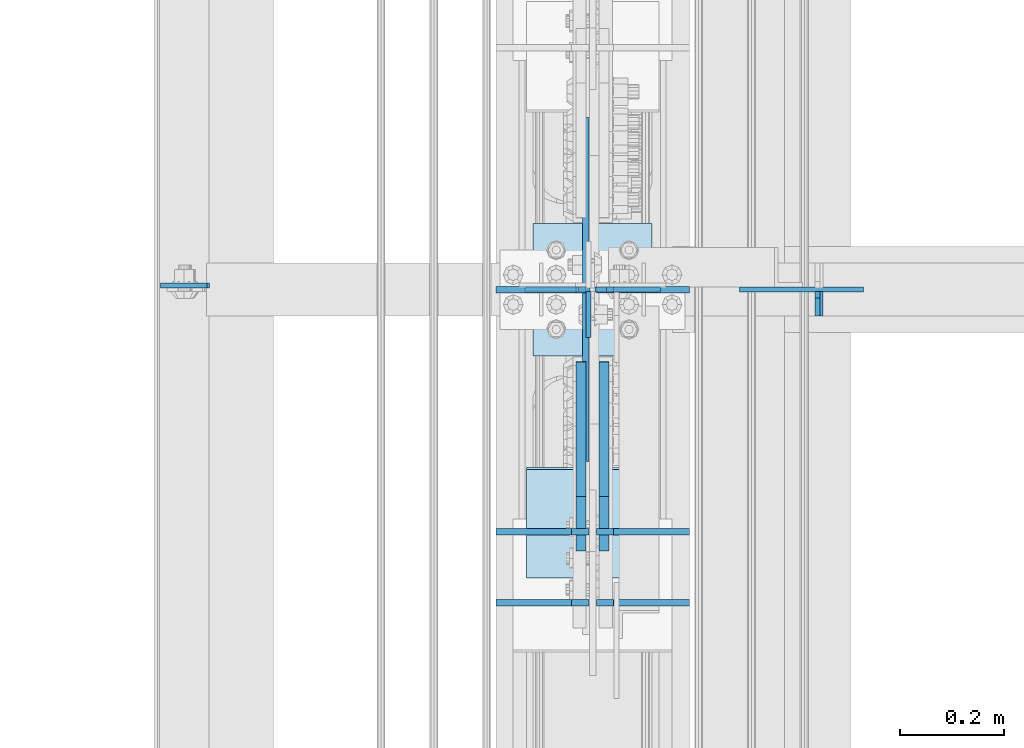
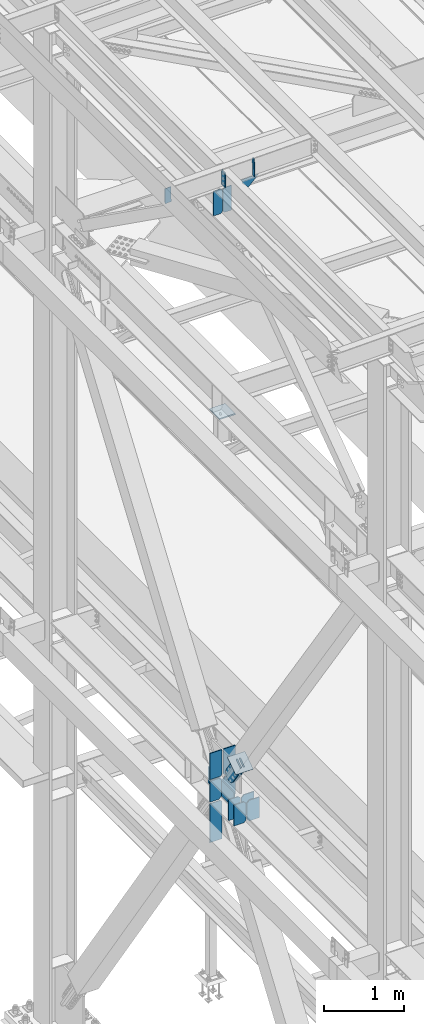
# One storey, part 3254 of 3843: 20 plates, 8 elements without a shape of their own.
"""IFC2X3 building model written with IfcOpenShell, lengths in millimetres."""

from ifc_helpers import new_model, si_unit, frame, origin_with_axes, place, context, subcontext, project, spatial, faceted_brep, material, type_object, element, aggregate, save


model = new_model("IFC2X3")

# Units and contexts
model_context = context("Model", 3, precision=1e-05, world=origin_with_axes())
body_context = subcontext(model_context, "Body", "Model", "MODEL_VIEW")
ifc_project = project(units=[si_unit("LENGTHUNIT", "METRE", prefix="MILLI"), si_unit("AREAUNIT", "SQUARE_METRE"), si_unit("VOLUMEUNIT", "CUBIC_METRE"), si_unit("MASSUNIT", "GRAM", prefix="KILO"), si_unit("TIMEUNIT", "SECOND"), si_unit("PLANEANGLEUNIT", "RADIAN"), si_unit("SOLIDANGLEUNIT", "STERADIAN"), si_unit("THERMODYNAMICTEMPERATUREUNIT", "DEGREE_CELSIUS"), si_unit("LUMINOUSINTENSITYUNIT", "LUMEN")], contexts=[model_context])

# Site, building, storey
site_placement = place(None, origin_with_axes())
site = spatial("IfcSite", under=ifc_project, at=site_placement, CompositionType="ELEMENT")
building_placement = place(site_placement, origin_with_axes())
building = spatial("IfcBuilding", under=site, at=building_placement, Name="Undefined", CompositionType="ELEMENT")
storey_placement = place(building_placement, origin_with_axes())
storey = spatial("IfcBuildingStorey", under=building, at=storey_placement, Name="Undefined", CompositionType="ELEMENT", Elevation=0.0)

# Assembly, plate
assembly_1_placement = place(storey_placement, origin_with_axes())
assembly_1 = element("IfcElementAssembly", 1, at=assembly_1_placement, inside=storey, Name="BEAM", AssemblyPlace="NOTDEFINED", PredefinedType="RIGID_FRAME")
ifc_material_1 = material(Name="STEEL/A572-50")
plate_type_1 = type_object("IfcPlateType", PredefinedType="NOTDEFINED")
plate_1_placement = place(assembly_1_placement, frame((36568.0624999392, 54733.8249999999, 45691.4946293704), z_axis=(0.0, -1.0, 0.0), x_axis=(0.0, 0.0, -1.0)))
plate_1 = element("IfcPlate", 2, at=plate_1_placement, type_object=plate_type_1, material=ifc_material_1, Name="PLATE", context=body_context, shape_type="Brep", body=[
    faceted_brep([(0.0, -4.76249999999709, 0.0), (0.0, -4.76249999999709, 88.9000015258789), (0.0, 4.76249999999709, 88.9000015258789), (0.0, 4.76249999999709, 0.0), (228.600006102781, -4.7625000004191, 88.9000015257589), (228.600006102781, 4.76249999954598, 88.9000015257443), (228.600006103079, -4.7625000004482, 7.27595761418343e-12), (228.600006103079, 4.76249999954598, -7.27595761418343e-12)], [[[0, 1, 2, 3]], [[1, 4, 5, 2]], [[4, 6, 7, 5]], [[6, 0, 3, 7]], [[5, 7, 3, 2]], [[6, 4, 1, 0]]]),
])

assembly_2_placement = place(storey_placement, origin_with_axes())
assembly_2 = element("IfcElementAssembly", 3, at=assembly_2_placement, inside=storey, Name="BEAM", AssemblyPlace="NOTDEFINED", PredefinedType="RIGID_FRAME")
plate_2_placement = place(assembly_2_placement, frame((35746.5416190253, 54744.9374999999, 45673.9373921795), z_axis=(0.999776270257024, 0.0, 0.0211520550054619), x_axis=(0.0211520550054438, 0.0, -0.999776270257025)))
plate_2 = element("IfcPlate", 4, at=plate_2_placement, type_object=plate_type_1, material=ifc_material_1, Name="PLATE", context=body_context, shape_type="Brep", body=[
    faceted_brep([(0.0, -4.76249999999709, 0.0), (0.0, -4.76249999999709, 88.9000015258789), (0.0, 4.76249999999709, 88.9000015258789), (0.0, 4.76249999999709, 0.0), (228.600006102781, -4.7625000004191, 88.9000015257589), (228.600006102781, 4.76249999954598, 88.9000015257443), (228.600006103079, -4.7625000004482, 7.27595761418343e-12), (228.600006103079, 4.76249999954598, -7.27595761418343e-12)], [[[0, 1, 2, 3]], [[1, 4, 5, 2]], [[4, 6, 7, 5]], [[6, 0, 3, 7]], [[5, 7, 3, 2]], [[6, 4, 1, 0]]]),
])
aggregate(assembly_2, [plate_2])

# Plate
plate_type_2 = type_object("IfcPlateType", PredefinedType="NOTDEFINED")
plate_3_placement = place(assembly_1_placement, frame((37013.8586767963, 54686.1999999999, 45441.929399494), z_axis=(-0.0211520980073474, 0.0, 0.999776269347241), x_axis=(0.0, 1.0, 0.0)))
plate_3 = element("IfcPlate", 5, at=plate_3_placement, type_object=plate_type_2, material=ifc_material_1, Name="STIFFENER", context=body_context, shape_type="Brep", body=[
    faceted_brep([(0.0, -4.76249999999709, 0.0), (0.0, -4.7624999997206, 285.749999997672), (0.0, 4.7625000002663, 285.749999997664), (0.0, 4.76249999999709, 0.0), (34.9250001907349, -4.7624999997206, 285.749999997672), (34.9250001907349, 4.7625000002663, 285.749999997664), (47.625, -4.76249999972788, 273.050000188428), (47.625, 4.76250000025902, 273.050000188421), (47.625, -4.76249999998981, 12.6999998092579), (47.625, 4.76249999999709, 12.6999998092506), (34.9250001907349, -4.76249999999709, 1.45519152283669e-11), (34.9250001907349, 4.76249999998254, 0.0)], [[[0, 1, 2, 3]], [[1, 4, 5, 2]], [[4, 6, 7, 5]], [[6, 8, 9, 7]], [[8, 10, 11, 9]], [[10, 0, 3, 11]], [[5, 7, 9, 11, 3, 2]], [[10, 8, 6, 4, 1, 0]]]),
])

# Assembly, plates
assembly_3_placement = place(storey_placement, origin_with_axes())
assembly_3 = element("IfcElementAssembly", 6, at=assembly_3_placement, inside=storey, Name="BEAM", AssemblyPlace="NOTDEFINED", PredefinedType="RIGID_FRAME")
plate_type_3 = type_object("IfcPlateType", PredefinedType="NOTDEFINED")
plate_4_placement = place(assembly_3_placement, frame((36568.85625, 54135.7343749999, 36093.4), z_axis=(-1.0, 0.0, 0.0), x_axis=(0.0, 0.0, 1.0)))
plate_4 = element("IfcPlate", 7, at=plate_4_placement, type_object=plate_type_3, material=ifc_material_1, Name="CB_BEAM", context=body_context, shape_type="Brep", body=[
    faceted_brep([(0.0, -6.34999999999854, 33.3375015258789), (0.0, -6.34999999999854, 178.59375), (0.0, 6.34999999999854, 178.59375), (0.0, 6.34999999999854, 33.3375015258789), (317.499999999985, -6.34999999999854, 178.59375), (317.499999999985, 6.34999999999854, 178.59375), (317.499999999985, -6.34999999999854, 33.3375015258789), (317.499999999985, 6.34999999999854, 33.3375015258789), (284.162498474107, -6.34999999999854, 0.0), (284.162498474107, 6.34999999999854, 0.0), (33.3375015258789, -6.34999999999854, 0.0), (33.3375015258789, 6.34999999999854, 0.0)], [[[0, 1, 2, 3]], [[1, 4, 5, 2]], [[4, 6, 7, 5]], [[6, 8, 9, 7]], [[8, 10, 11, 9]], [[10, 0, 3, 11]], [[5, 7, 9, 11, 3, 2]], [[10, 8, 6, 4, 1, 0]]]),
])
plate_5_placement = place(assembly_3_placement, frame((36583.14375, 54135.734375, 36093.4), z_axis=(1.0, 0.0, 0.0), x_axis=(0.0, 0.0, 1.0)))
plate_5 = element("IfcPlate", 8, at=plate_5_placement, type_object=plate_type_3, material=ifc_material_1, Name="CB_BEAM", context=body_context, shape_type="Brep", body=[
    faceted_brep([(0.0, -6.34999999999854, 33.3375015258789), (0.0, -6.34999999999854, 178.59375), (0.0, 6.34999999999854, 178.59375), (0.0, 6.34999999999854, 33.3375015258789), (317.499999999985, -6.34999999999854, 178.59375), (317.499999999985, 6.34999999999854, 178.59375), (317.499999999985, -6.34999999999854, 33.3375015258789), (317.499999999985, 6.34999999999854, 33.3375015258789), (284.162498474107, -6.34999999999854, 0.0), (284.162498474107, 6.34999999999854, 0.0), (33.3375015258789, -6.34999999999854, 0.0), (33.3375015258789, 6.34999999999854, 0.0)], [[[0, 1, 2, 3]], [[1, 4, 5, 2]], [[4, 6, 7, 5]], [[6, 8, 9, 7]], [[8, 10, 11, 9]], [[10, 0, 3, 11]], [[5, 7, 9, 11, 3, 2]], [[10, 8, 6, 4, 1, 0]]]),
])
plate_6_placement = place(assembly_3_placement, frame((36568.85625, 54272.2593749999, 36093.4), z_axis=(-1.0, 0.0, 0.0), x_axis=(0.0, 0.0, 1.0)))
plate_6 = element("IfcPlate", 9, at=plate_6_placement, type_object=plate_type_3, material=ifc_material_1, Name="CB_BEAM", context=body_context, shape_type="Brep", body=[
    faceted_brep([(0.0, -6.34999999999854, 33.3375015258789), (0.0, -6.34999999999854, 178.59375), (0.0, 6.34999999999854, 178.59375), (0.0, 6.34999999999854, 33.3375015258789), (317.499999999985, -6.34999999999854, 178.59375), (317.499999999985, 6.34999999999854, 178.59375), (317.499999999985, -6.34999999999854, 33.3375015258789), (317.499999999985, 6.34999999999854, 33.3375015258789), (284.162498474107, -6.34999999999854, 0.0), (284.162498474107, 6.34999999999854, 0.0), (33.3375015258789, -6.34999999999854, 0.0), (33.3375015258789, 6.34999999999854, 0.0)], [[[0, 1, 2, 3]], [[1, 4, 5, 2]], [[4, 6, 7, 5]], [[6, 8, 9, 7]], [[8, 10, 11, 9]], [[10, 0, 3, 11]], [[5, 7, 9, 11, 3, 2]], [[10, 8, 6, 4, 1, 0]]]),
])
plate_7_placement = place(assembly_3_placement, frame((36583.14375, 54272.259375, 36093.4), z_axis=(1.0, 0.0, 0.0), x_axis=(0.0, 0.0, 1.0)))
plate_7 = element("IfcPlate", 10, at=plate_7_placement, type_object=plate_type_3, material=ifc_material_1, Name="CB_BEAM", context=body_context, shape_type="Brep", body=[
    faceted_brep([(0.0, -6.34999999999854, 33.3375015258789), (0.0, -6.34999999999854, 178.59375), (0.0, 6.34999999999854, 178.59375), (0.0, 6.34999999999854, 33.3375015258789), (317.499999999985, -6.34999999999854, 178.59375), (317.499999999985, 6.34999999999854, 178.59375), (317.499999999985, -6.34999999999854, 33.3375015258789), (317.499999999985, 6.34999999999854, 33.3375015258789), (284.162498474107, -6.34999999999854, 0.0), (284.162498474107, 6.34999999999854, 0.0), (33.3375015258789, -6.34999999999854, 0.0), (33.3375015258789, 6.34999999999854, 0.0)], [[[0, 1, 2, 3]], [[1, 4, 5, 2]], [[4, 6, 7, 5]], [[6, 8, 9, 7]], [[8, 10, 11, 9]], [[10, 0, 3, 11]], [[5, 7, 9, 11, 3, 2]], [[10, 8, 6, 4, 1, 0]]]),
])
plate_8_placement = place(assembly_3_placement, frame((36583.14375, 54737.0, 36093.4), z_axis=(1.0, 0.0, 0.0), x_axis=(0.0, 0.0, 1.0)))
plate_8 = element("IfcPlate", 11, at=plate_8_placement, type_object=plate_type_3, material=ifc_material_1, Name="CB_BEAM", context=body_context, shape_type="Brep", body=[
    faceted_brep([(0.0, -6.34999999999854, 33.3375015258789), (0.0, -6.34999999999854, 178.59375), (0.0, 6.34999999999854, 178.59375), (0.0, 6.34999999999854, 33.3375015258789), (317.499999999985, -6.34999999999854, 178.59375), (317.499999999985, 6.34999999999854, 178.59375), (317.499999999985, -6.34999999999854, 33.3375015258789), (317.499999999985, 6.34999999999854, 33.3375015258789), (284.162498474107, -6.34999999999854, 0.0), (284.162498474107, 6.34999999999854, 0.0), (33.3375015258789, -6.34999999999854, 0.0), (33.3375015258789, 6.34999999999854, 0.0)], [[[0, 1, 2, 3]], [[1, 4, 5, 2]], [[4, 6, 7, 5]], [[6, 8, 9, 7]], [[8, 10, 11, 9]], [[10, 0, 3, 11]], [[5, 7, 9, 11, 3, 2]], [[10, 8, 6, 4, 1, 0]]]),
])

assembly_4_placement = place(storey_placement, origin_with_axes())
assembly_4 = element("IfcElementAssembly", 12, at=assembly_4_placement, inside=storey, Name="BEAM", AssemblyPlace="NOTDEFINED", PredefinedType="RIGID_FRAME")
plate_type_4 = type_object("IfcPlateType", PredefinedType="NOTDEFINED")
plate_9_placement = place(assembly_4_placement, frame((36706.1750000347, 54736.9999985987, 45021.5000000004), z_axis=(0.0, 0.0, 1.0), x_axis=(-1.0, 0.0, 0.0)))
plate_9 = element("IfcPlate", 13, at=plate_9_placement, type_object=plate_type_4, material=ifc_material_1, Name="STIFFENER", context=body_context, shape_type="Brep", body=[
    faceted_brep([(0.0, -4.76249999999709, 0.0), (0.0, -4.76249999999709, 377.824999997538), (0.0, 4.76249999999709, 377.824999997538), (0.0, 4.76249999999709, 0.0), (103.187499618536, -4.76249999999709, 377.824999997538), (103.187499618536, 4.76249999999709, 377.824999997538), (125.412500000006, -4.76249999999709, 355.599999616068), (125.412500000006, 4.76249999999709, 355.599999616068), (125.412500000006, -4.76249999999709, 22.2250003814697), (125.412500000006, 4.76249999999709, 22.2250003814697), (103.187499618536, -4.76249999999709, 0.0), (103.187499618536, 4.76249999999709, 0.0)], [[[0, 1, 2, 3]], [[1, 4, 5, 2]], [[4, 6, 7, 5]], [[6, 8, 9, 7]], [[8, 10, 11, 9]], [[10, 0, 3, 11]], [[5, 7, 9, 11, 3, 2]], [[10, 8, 6, 4, 1, 0]]]),
])
plate_10_placement = place(assembly_4_placement, frame((36571.2375000347, 54736.9999985987, 45021.5000000004), z_axis=(0.0, 0.0, 1.0), x_axis=(-1.0, 0.0, 0.0)))
plate_10 = element("IfcPlate", 14, at=plate_10_placement, type_object=plate_type_4, material=ifc_material_1, Name="STIFFENER", context=body_context, shape_type="Brep", body=[
    faceted_brep([(0.0, -4.76249999999709, 22.2250003814697), (0.0, -4.76249999999709, 355.599999616068), (0.0, 4.76249999999709, 355.599999616068), (0.0, 4.76249999999709, 22.2250003814697), (22.2250003814697, -4.76249999999709, 377.824999997538), (22.2250003814697, 4.76249999999709, 377.824999997538), (125.412500000006, -4.76249999999709, 377.824999997538), (125.412500000006, 4.76249999999709, 377.824999997538), (125.412500000006, -4.76249999999709, 0.0), (125.412500000006, 4.76249999999709, 0.0), (22.2250003814697, -4.76249999999709, 0.0), (22.2250003814697, 4.76249999999709, 0.0)], [[[0, 1, 2, 3]], [[1, 4, 5, 2]], [[4, 6, 7, 5]], [[6, 8, 9, 7]], [[8, 10, 11, 9]], [[10, 0, 3, 11]], [[5, 7, 9, 11, 3, 2]], [[10, 8, 6, 4, 1, 0]]]),
])
aggregate(assembly_4, [plate_9, plate_10])

# Plate
plate_type_5 = type_object("IfcPlateType", PredefinedType="NOTDEFINED")
plate_11_placement = place(assembly_1_placement, frame((36857.7258091626, 54736.9999985331, 45427.5111359823), z_axis=(0.0211520550054438, 0.0, -0.999776270257025), x_axis=(0.999776270257024, 0.0, 0.0211520550054619)))
plate_11 = element("IfcPlate", 15, at=plate_11_placement, type_object=plate_type_5, material=ifc_material_1, Name="PLATE", context=body_context, shape_type="Brep", body=[
    faceted_brep([(0.0, -4.76249999999709, 0.0), (-0.000271083736151922, -4.7625000001135, 52.4356396771473), (-0.000271083757979795, 4.76249999988067, 52.4356396771473), (0.0, 4.76249999999709, 0.0), (87.8825045197955, -4.76250000033178, 144.117664585436), (87.8825045197736, 4.7624999996624, 144.11766458545), (238.230258310934, -4.76249999999709, -2.47382558882236e-10), (238.230258310919, 4.76249999999709, -2.25554686039686e-10)], [[[0, 1, 2, 3]], [[1, 4, 5, 2]], [[4, 6, 7, 5]], [[6, 0, 3, 7]], [[5, 7, 3, 2]], [[6, 4, 1, 0]]]),
])

aggregate(assembly_1, [plate_3, plate_11, plate_1])

plate_type_6 = type_object("IfcPlateType", PredefinedType="NOTDEFINED")
plate_12_placement = place(assembly_3_placement, frame((36563.3, 54736.9999983235, 35473.878125), z_axis=(-1.0, 0.0, 0.0), x_axis=(0.0, 0.0, 1.0)))
plate_12 = element("IfcPlate", 16, at=plate_12_placement, type_object=plate_type_6, material=ifc_material_1, Name="CB", context=body_context, shape_type="Brep", body=[
    faceted_brep([(0.0, -6.3499999046162, 0.0), (0.0, -6.34999999999854, 173.037500000006), (0.0, 6.34999999999854, 173.037500000006), (7.27595761418343e-12, 6.3499999046162, 0.0), (594.065321849368, -6.34999999999854, 173.037500000006), (594.065321849368, 6.34999999999854, 173.037500000006), (594.065321849368, -6.34999999999854, 19.0499992370605), (594.065321849368, 6.34999999999854, 19.0499992370605), (575.015322612308, -6.34999999999854, 0.0), (575.015322612308, 6.34999999999854, 0.0)], [[[0, 1, 2, 3]], [[1, 4, 5, 2]], [[4, 6, 7, 5]], [[6, 8, 9, 7]], [[8, 0, 3, 9]], [[5, 7, 9, 3, 2]], [[8, 6, 4, 1, 0]]]),
])

plate_13_placement = place(assembly_3_placement, frame((36563.3, 54737.0, 36436.3), z_axis=(-1.0, 0.0, 0.0), x_axis=(0.0, 0.0, 1.0)))
plate_13 = element("IfcPlate", 17, at=plate_13_placement, type_object=plate_type_6, material=ifc_material_1, Name="CB", context=body_context, shape_type="Brep", body=[
    faceted_brep([(0.0, -6.34999999999854, 19.0499992370605), (0.0, -6.34999999999854, 173.037500000006), (0.0, 6.34999999999854, 173.037500000006), (0.0, 6.34999999999854, 19.0499992370605), (398.583313588024, -6.34999999999854, 173.037500000006), (398.583313588024, 6.34999999999854, 173.037500000006), (398.583313588024, -6.34999999999854, 0.0), (398.583313588024, 6.34999999999854, 0.0), (19.0499992370605, -6.34999999999854, 0.0), (19.0499992370605, 6.34999999999854, 0.0)], [[[0, 1, 2, 3]], [[1, 4, 5, 2]], [[4, 6, 7, 5]], [[6, 8, 9, 7]], [[8, 0, 3, 9]], [[5, 7, 9, 3, 2]], [[8, 6, 4, 1, 0]]]),
])

plate_14_placement = place(assembly_3_placement, frame((36588.7, 54737.0, 36436.3), z_axis=(1.0, 0.0, 0.0), x_axis=(0.0, 0.0, 1.0)))
plate_14 = element("IfcPlate", 18, at=plate_14_placement, type_object=plate_type_6, material=ifc_material_1, Name="CB", context=body_context, shape_type="Brep", body=[
    faceted_brep([(0.0, -6.34999999999854, 19.0499992370605), (0.0, -6.34999999999854, 173.037500000006), (0.0, 6.34999999999854, 173.037500000006), (0.0, 6.34999999999854, 19.0499992370605), (398.583313588024, -6.34999999999854, 173.037500000006), (398.583313588024, 6.34999999999854, 173.037500000006), (398.583313588024, -6.34999999999854, 0.0), (398.583313588024, 6.34999999999854, 0.0), (19.0499992370605, -6.34999999999854, 0.0), (19.0499992370605, 6.34999999999854, 0.0)], [[[0, 1, 2, 3]], [[1, 4, 5, 2]], [[4, 6, 7, 5]], [[6, 8, 9, 7]], [[8, 0, 3, 9]], [[5, 7, 9, 3, 2]], [[8, 6, 4, 1, 0]]]),
])

plate_type_7 = type_object("IfcPlateType", PredefinedType="NOTDEFINED")
plate_15_placement = place(assembly_3_placement, frame((36562.5062499996, 54406.8, 36379.1499984745), z_axis=(0.0, 0.0, -1.0), x_axis=(0.0, 1.0, 0.0)))
plate_15 = element("IfcPlate", 19, at=plate_15_placement, type_object=plate_type_7, material=ifc_material_1, Name="PLATE", context=body_context, shape_type="Brep", body=[
    faceted_brep([(7.27595761418343e-12, 6.3499999046162, 0.0), (660.400000000001, 6.34999999999854, 3.78349795937538e-10), (660.400000000001, -6.34999999999854, 7.33234865510167), (0.0, -6.34999999999854, 7.33234841687954), (660.400000000001, 6.34999999999854, 253.999996948616), (660.400000000001, -6.34999999999854, 246.667648296119), (0.0, -6.34999999999854, 246.667648296119), (0.0, 6.34999999999854, 253.999996948245)], [[[0, 1, 2, 3]], [[2, 1, 4, 5]], [[3, 2, 5, 6]], [[0, 3, 6, 7]], [[1, 0, 7, 4]], [[6, 5, 4, 7]]]),
])

# Assembly, plate
assembly_5_placement = place(storey_placement, origin_with_axes())
assembly_5 = element("IfcElementAssembly", 20, at=assembly_5_placement, inside=storey, AssemblyPlace="NOTDEFINED", PredefinedType="RIGID_FRAME")
ifc_material_2 = material(Name="STEEL/A36")
plate_type_8 = type_object("IfcPlateType", PredefinedType="NOTDEFINED")
plate_16_placement = place(assembly_5_placement, frame((36553.775, 54339.9017369435, 36931.3817340801), z_axis=(0.0, -0.819732546373648, -0.572746499261039), x_axis=(0.0, 0.572746499261054, -0.819732546373637)))
plate_16 = element("IfcPlate", 21, at=plate_16_placement, type_object=plate_type_8, material=ifc_material_2, context=body_context, shape_type="Brep", body=[
    faceted_brep([(0.0, -9.52500000000146, 0.0), (-1.04046193882823e-09, -9.52499999999418, 127.02645557576), (-1.04046193882823e-09, 9.52499999999418, 127.02645557576), (0.0, 9.52500000000146, 0.0), (57.1500000014785, -9.52500000000146, 127.026455576495), (57.1500000014785, 9.52500000000146, 127.026455576495), (158.750000004118, -9.52500000000146, 160.350727790756), (158.750000004118, 9.52500000000146, 160.350727790756), (377.429297677212, -9.52500000000146, 160.35072779077), (377.429297677212, 9.52500000000146, 160.35072779077), (414.487405142921, -9.52500000000146, 152.979411904162), (414.487405142921, 9.52500000000146, 152.979411904162), (445.90375167958, -9.52500000000146, 131.987680266906), (445.90375167958, 9.52500000000146, 131.987680266906), (466.895483316825, -9.52500000000146, 100.571333730262), (466.895483316825, 9.52500000000146, 100.571333730262), (474.266799203455, -9.52500000000146, 63.5132293120041), (474.266799203455, 9.52500000000146, 63.5132293120041), (466.895483316854, -9.52500000000146, 26.4551218462766), (466.895483316854, 9.52500000000146, 26.4551218462766), (445.90375167958, -9.52500000000146, -4.96122469036709), (445.90375167958, 9.52500000000146, -4.96122469036709), (414.487405142936, -9.52500000000146, -25.9529563276265), (414.487405142936, 9.52500000000146, -25.9529563276265), (377.429299200972, -9.52500000000146, -33.3242722142422), (377.429299200972, 9.52500000000146, -33.3242722142422), (158.750000004104, -9.52500000000146, -33.3242722142495), (158.750000004104, 9.52500000000146, -33.3242722142495), (57.1500000014785, -9.52500000000146, 3.63797880709171e-12), (57.1500000014785, 9.52500000000146, 3.63797880709171e-12)], [[[0, 1, 2, 3]], [[1, 4, 5, 2]], [[4, 6, 7, 5]], [[6, 8, 9, 7]], [[8, 10, 11, 9]], [[10, 12, 13, 11]], [[12, 14, 15, 13]], [[14, 16, 17, 15]], [[16, 18, 19, 17]], [[18, 20, 21, 19]], [[20, 22, 23, 21]], [[22, 24, 25, 23]], [[24, 26, 27, 25]], [[26, 28, 29, 27]], [[28, 0, 3, 29]], [[5, 7, 9, 11, 13, 15, 17, 19, 21, 23, 25, 27, 29, 3, 2]], [[28, 26, 24, 22, 20, 18, 16, 14, 12, 10, 8, 6, 4, 1, 0]]]),
])
aggregate(assembly_5, [plate_16])

assembly_6_placement = place(storey_placement, origin_with_axes())
assembly_6 = element("IfcElementAssembly", 22, at=assembly_6_placement, inside=storey, AssemblyPlace="NOTDEFINED", PredefinedType="RIGID_FRAME")
plate_17_placement = place(assembly_6_placement, frame((36598.225, 54339.9017369435, 36931.3817340801), z_axis=(0.0, -0.819732546373648, -0.572746499261039), x_axis=(0.0, 0.572746499261054, -0.819732546373637)))
plate_17 = element("IfcPlate", 23, at=plate_17_placement, type_object=plate_type_8, material=ifc_material_2, context=body_context, shape_type="Brep", body=[
    faceted_brep([(0.0, -9.52500000000146, 0.0), (-1.04046193882823e-09, -9.52499999999418, 127.02645557576), (-1.04046193882823e-09, 9.52499999999418, 127.02645557576), (0.0, 9.52500000000146, 0.0), (57.1500000014785, -9.52500000000146, 127.026455576495), (57.1500000014785, 9.52500000000146, 127.026455576495), (158.750000004118, -9.52500000000146, 160.350727790756), (158.750000004118, 9.52500000000146, 160.350727790756), (377.429297677212, -9.52500000000146, 160.35072779077), (377.429297677212, 9.52500000000146, 160.35072779077), (414.487405142921, -9.52500000000146, 152.979411904162), (414.487405142921, 9.52500000000146, 152.979411904162), (445.90375167958, -9.52500000000146, 131.987680266906), (445.90375167958, 9.52500000000146, 131.987680266906), (466.895483316825, -9.52500000000146, 100.571333730262), (466.895483316825, 9.52500000000146, 100.571333730262), (474.266799203455, -9.52500000000146, 63.5132293120041), (474.266799203455, 9.52500000000146, 63.5132293120041), (466.895483316854, -9.52500000000146, 26.4551218462766), (466.895483316854, 9.52500000000146, 26.4551218462766), (445.90375167958, -9.52500000000146, -4.96122469036709), (445.90375167958, 9.52500000000146, -4.96122469036709), (414.487405142936, -9.52500000000146, -25.9529563276265), (414.487405142936, 9.52500000000146, -25.9529563276265), (377.429299200972, -9.52500000000146, -33.3242722142422), (377.429299200972, 9.52500000000146, -33.3242722142422), (158.750000004104, -9.52500000000146, -33.3242722142495), (158.750000004104, 9.52500000000146, -33.3242722142495), (57.1500000014785, -9.52500000000146, 3.63797880709171e-12), (57.1500000014785, 9.52500000000146, 3.63797880709171e-12)], [[[0, 1, 2, 3]], [[1, 4, 5, 2]], [[4, 6, 7, 5]], [[6, 8, 9, 7]], [[8, 10, 11, 9]], [[10, 12, 13, 11]], [[12, 14, 15, 13]], [[14, 16, 17, 15]], [[16, 18, 19, 17]], [[18, 20, 21, 19]], [[20, 22, 23, 21]], [[22, 24, 25, 23]], [[24, 26, 27, 25]], [[26, 28, 29, 27]], [[28, 0, 3, 29]], [[5, 7, 9, 11, 13, 15, 17, 19, 21, 23, 25, 27, 29, 3, 2]], [[28, 26, 24, 22, 20, 18, 16, 14, 12, 10, 8, 6, 4, 1, 0]]]),
])
aggregate(assembly_6, [plate_17])

assembly_7_placement = place(storey_placement, origin_with_axes())
assembly_7 = element("IfcElementAssembly", 24, at=assembly_7_placement, inside=storey, Name="Plate", AssemblyPlace="NOTDEFINED", PredefinedType="RIGID_FRAME")
plate_type_9 = type_object("IfcPlateType", PredefinedType="NOTDEFINED")
plate_18_placement = place(assembly_7_placement, frame((36449.0, 54185.5503134635, 36819.6632989095), z_axis=(0.0, 0.819732546373636, 0.572746499261056), x_axis=(1.0, 0.0, 0.0)))
plate_18 = element("IfcPlate", 25, at=plate_18_placement, type_object=plate_type_9, material=ifc_material_2, Name="Plate", context=body_context, shape_type="Brep", body=[
    faceted_brep([(0.0, -3.17499999999927, 0.0), (0.0, -3.17499999965185, 254.000000005151), (0.0, 3.17500000035216, 254.000000005166), (0.0, 3.17499999999927, 0.0), (254.0, -3.17499999965185, 254.000000005151), (254.0, 3.17500000035216, 254.000000005166), (254.0, -3.17500000000291, 0.0), (254.0, 3.17499999999927, 1.45519152283669e-11)], [[[0, 1, 2, 3]], [[1, 4, 5, 2]], [[4, 6, 7, 5]], [[6, 0, 3, 7]], [[5, 7, 3, 2]], [[6, 4, 1, 0]]]),
])
aggregate(assembly_7, [plate_18])

assembly_8_placement = place(storey_placement, origin_with_axes())
assembly_8 = element("IfcElementAssembly", 26, at=assembly_8_placement, inside=storey, Name="POST", AssemblyPlace="NOTDEFINED", PredefinedType="RIGID_FRAME")
plate_type_10 = type_object("IfcPlateType", PredefinedType="NOTDEFINED")
plate_19_placement = place(assembly_8_placement, frame((36461.700000099, 54864.0, 41986.2), z_axis=(0.0, -1.0, 0.0), x_axis=(1.0, 0.0, 0.0)))
plate_19 = element("IfcPlate", 27, at=plate_19_placement, type_object=plate_type_10, material=ifc_material_1, Name="PLATE", context=body_context, shape_type="Brep", body=[
    faceted_brep([(0.0, -9.52500000000146, 0.0), (0.0, -9.52500000000146, 254.0), (0.0, 9.52500000000146, 254.0), (0.0, 9.52500000000146, 0.0), (228.599999999999, -9.52500000000146, 254.0), (228.599999999999, 9.52500000000146, 254.0), (228.599999999999, -9.52500000000146, 0.0), (228.599999999999, 9.52500000000146, 0.0)], [[[0, 1, 2, 3]], [[1, 4, 5, 2]], [[4, 6, 7, 5]], [[6, 0, 3, 7]], [[5, 7, 3, 2]], [[6, 4, 1, 0]]]),
])
aggregate(assembly_8, [plate_19])

# Plate
plate_type_11 = type_object("IfcPlateType", PredefinedType="NOTDEFINED")
plate_20_placement = place(assembly_3_placement, frame((36556.15625, 54737.0, 36093.4), z_axis=(-1.0, 0.0, 0.0), x_axis=(0.0, 0.0, 1.0)))
plate_20 = element("IfcPlate", 28, at=plate_20_placement, type_object=plate_type_11, material=ifc_material_1, Name="CB_BEAM", context=body_context, shape_type="Brep", body=[
    faceted_brep([(0.0, -6.34999999999854, 33.3375015258789), (0.0, -6.34999999999854, 165.893750000003), (0.0, 6.34999999999854, 165.893750000003), (0.0, 6.34999999999854, 33.3375015258789), (317.5, -6.34999999999854, 165.893750000003), (317.5, 6.34999999999854, 165.893750000003), (317.499999999985, -6.34999999999854, 33.3375015258789), (317.499999999985, 6.34999999999854, 33.3375015258789), (284.162498474107, -6.34999999999854, 0.0), (284.162498474107, 6.34999999999854, 0.0), (33.3375015258789, -6.34999999999854, 0.0), (33.3375015258789, 6.34999999999854, 0.0)], [[[0, 1, 2, 3]], [[1, 4, 5, 2]], [[4, 6, 7, 5]], [[6, 8, 9, 7]], [[8, 10, 11, 9]], [[10, 0, 3, 11]], [[5, 7, 9, 11, 3, 2]], [[10, 8, 6, 4, 1, 0]]]),
])

aggregate(assembly_3, [plate_12, plate_4, plate_5, plate_6, plate_7, plate_15, plate_20, plate_8, plate_13, plate_14])

save(model, "model.ifc")
